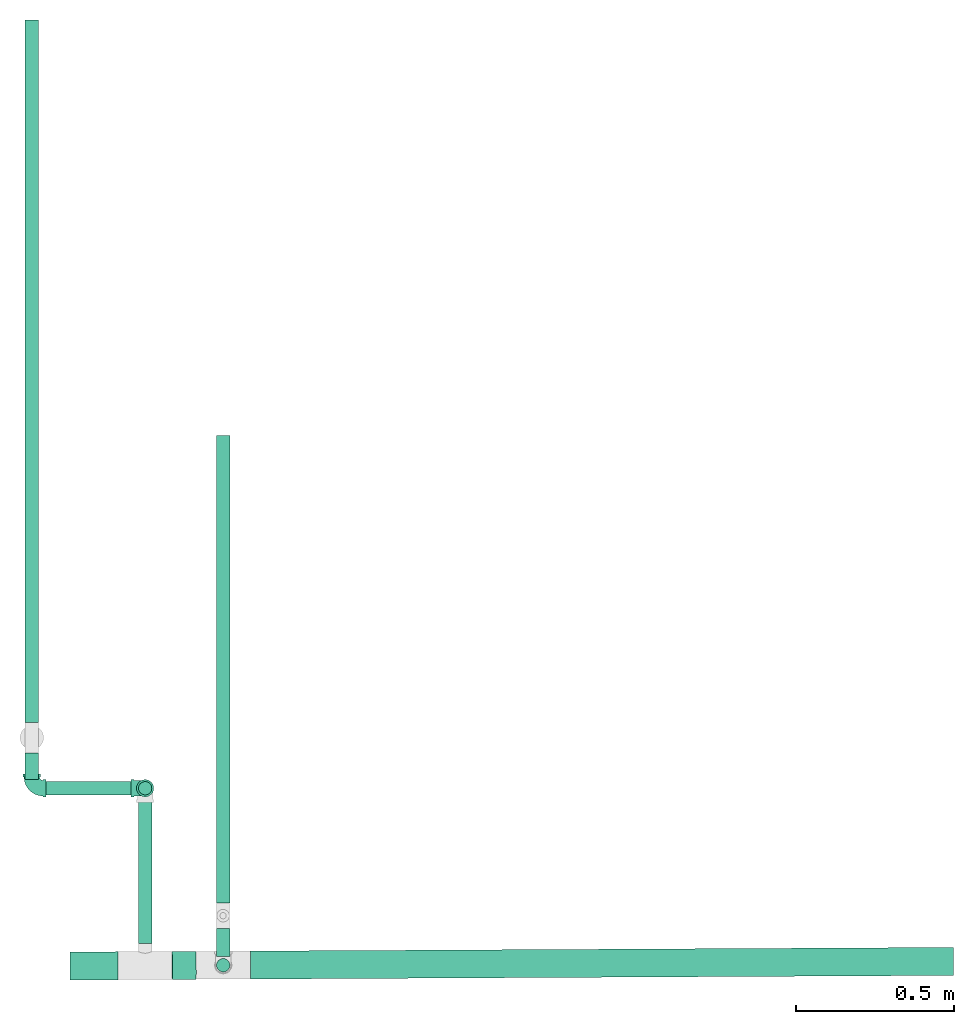
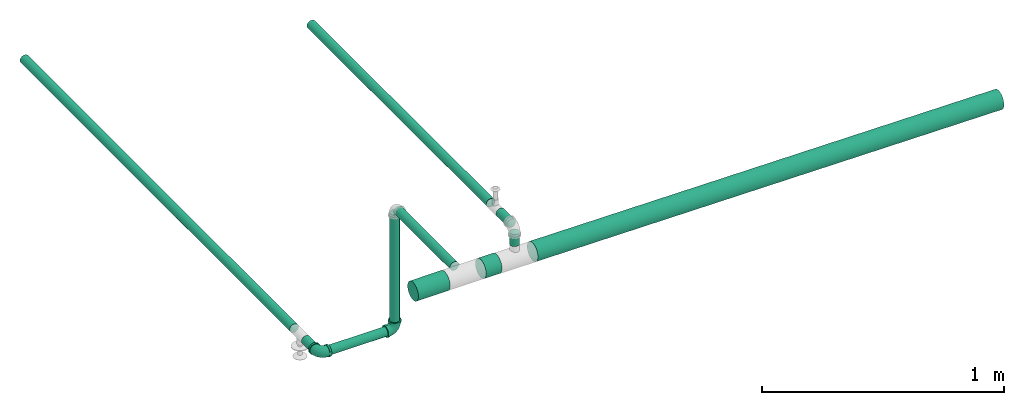
# One storey, part 1 of 7: 11 pipe segments, 2 pipe fittings.
"""IFC4 building model written with IfcOpenShell, lengths in millimetres."""

from ifc_helpers import new_model, entity, si_unit, converted_unit, derived_unit, direction, frame, frame_2d, origin, origin_2d_with_axis, place, context, subcontext, project, spatial, circle, extrude, source, transform, mapped, type_object, type_shapes, element, save


model = new_model("IFC4")

# Units and contexts
model_context = context("Model", 3, precision=0.01, world=origin(), true_north=direction((6.12303176911189e-17, 1.0)))
body_context = subcontext(model_context, "Body", "Model", "MODEL_VIEW")
ifc_project = project(units=[si_unit("LENGTHUNIT", "METRE", prefix="MILLI"), si_unit("AREAUNIT", "SQUARE_METRE"), si_unit("VOLUMEUNIT", "CUBIC_METRE"), converted_unit("PLANEANGLEUNIT", "DEGREE", entity("IfcRatioMeasure", 0.0174532925199433), si_unit("PLANEANGLEUNIT", "RADIAN"), dimensions=[0, 0, 0, 0, 0, 0, 0]), si_unit("MASSUNIT", "GRAM", prefix="KILO"), derived_unit("MASSDENSITYUNIT", [(si_unit("MASSUNIT", "GRAM", prefix="KILO"), 1), (si_unit("LENGTHUNIT", "METRE"), -3)]), derived_unit("MOMENTOFINERTIAUNIT", [(si_unit("LENGTHUNIT", "METRE"), 4)]), si_unit("TIMEUNIT", "SECOND"), si_unit("FREQUENCYUNIT", "HERTZ"), si_unit("THERMODYNAMICTEMPERATUREUNIT", "DEGREE_CELSIUS"), derived_unit("THERMALTRANSMITTANCEUNIT", [(si_unit("MASSUNIT", "GRAM", prefix="KILO"), 1), (si_unit("THERMODYNAMICTEMPERATUREUNIT", "KELVIN"), -1), (si_unit("TIMEUNIT", "SECOND"), -3)]), derived_unit("VOLUMETRICFLOWRATEUNIT", [(si_unit("LENGTHUNIT", "METRE"), 3), (si_unit("TIMEUNIT", "SECOND"), -1)]), si_unit("ELECTRICCURRENTUNIT", "AMPERE"), si_unit("ELECTRICVOLTAGEUNIT", "VOLT"), si_unit("POWERUNIT", "WATT"), si_unit("FORCEUNIT", "NEWTON", prefix="KILO"), si_unit("ILLUMINANCEUNIT", "LUX"), si_unit("LUMINOUSFLUXUNIT", "LUMEN"), si_unit("LUMINOUSINTENSITYUNIT", "CANDELA"), derived_unit("USERDEFINED", [(si_unit("MASSUNIT", "GRAM", prefix="KILO"), -1), (si_unit("LENGTHUNIT", "METRE"), -2), (si_unit("TIMEUNIT", "SECOND"), 3), (si_unit("LUMINOUSFLUXUNIT", "LUMEN"), 1)]), derived_unit("LINEARVELOCITYUNIT", [(si_unit("LENGTHUNIT", "METRE"), 1), (si_unit("TIMEUNIT", "SECOND"), -1)]), si_unit("PRESSUREUNIT", "PASCAL"), derived_unit("USERDEFINED", [(si_unit("LENGTHUNIT", "METRE"), -2), (si_unit("MASSUNIT", "GRAM", prefix="KILO"), 1), (si_unit("TIMEUNIT", "SECOND"), -2)]), derived_unit("LINEARFORCEUNIT", [(si_unit("MASSUNIT", "GRAM", prefix="KILO"), 1), (si_unit("LENGTHUNIT", "METRE"), 1), (si_unit("TIMEUNIT", "SECOND"), -2), (si_unit("LENGTHUNIT", "METRE"), -1)]), derived_unit("PLANARFORCEUNIT", [(si_unit("MASSUNIT", "GRAM", prefix="KILO"), 1), (si_unit("LENGTHUNIT", "METRE"), 1), (si_unit("TIMEUNIT", "SECOND"), -2), (si_unit("LENGTHUNIT", "METRE"), -2)])], contexts=[model_context])

# Site, building, storey
site_placement = place(None, origin())
site = spatial("IfcSite", under=ifc_project, at=site_placement, CompositionType="ELEMENT")
building_placement = place(site_placement, origin())
building = spatial("IfcBuilding", under=site, at=building_placement, CompositionType="ELEMENT")
storey_placement = place(building_placement, origin())
storey = spatial("IfcBuildingStorey", under=building, at=storey_placement, Name="Ebene 1", CompositionType="ELEMENT", Elevation=0.0)

# Pipe segments
pipe_segment_type = type_object("IfcPipeSegmentType", PredefinedType="NOTDEFINED")
pipe_segment_1_placement = place(storey_placement, frame((10752.7557828732, 94885.9064957971, 3701.44258339486)))
element("IfcPipeSegment", 1, at=pipe_segment_1_placement, inside=storey, type_object=pipe_segment_type, Name="2557", PredefinedType="NOTDEFINED", context=body_context, shape_type="SweptSolid", body=[
    extrude(circle(Radius=21.2, at=frame_2d((-9.62819385403469e-17, -1.73260207267188e-11), x_axis=(1.0, 0.0))), frame((22.7952719007182, 22.7952714513435, 0.00687981328899951), z_axis=(0.000177827791373917, 0.000272053912584841, 0.999999947181971), x_axis=(-0.999999984188637, 0.0, 0.000177827797954731)), (0.0, 0.0, 1.0), 60.1939504814704),
])
pipe_segment_2_placement = place(storey_placement, frame((10859.4947030414, 94863.1160077717, 3565.27971953889)))
element("IfcPipeSegment", 2, at=pipe_segment_2_placement, inside=storey, type_object=pipe_segment_type, Name="2560", PredefinedType="NOTDEFINED", context=body_context, shape_type="SweptSolid", body=[
    extrude(circle(Radius=44.45, at=frame_2d((1.12120611250361e-14, -1.96686733078511e-14), x_axis=(1.0, 0.0))), frame((2.05993232708415, 46.0446765665555, 66.3052599404551), z_axis=(0.999945358552014, 0.00517681182842612, -0.00908187918759944), x_axis=(-0.00517702533472437, 0.99998659911455, 0.0)), (0.0, 0.0, 1.0), 2231.0163407344),
])
pipe_segment_3_placement = place(storey_placement, frame((10752.7664866952, 94935.7631204171, 3765.88563724049)))
element("IfcPipeSegment", 3, at=pipe_segment_3_placement, inside=storey, type_object=pipe_segment_type, Name="2566", PredefinedType="NOTDEFINED", context=body_context, shape_type="SweptSolid", body=[
    extrude(circle(Radius=21.2, at=frame_2d((0.0, -5.41433564649196e-13), x_axis=(1.0, 0.0))), frame((22.7952722359154, 0.0, 22.7952722359154), z_axis=(0.0, 1.0, 0.0), x_axis=(1.0, 0.0, 0.0)), (0.0, 0.0, 1.0), 90.0010953566384),
])
pipe_segment_4_placement = place(storey_placement, frame((10752.7664866952, 95105.7642157737, 3765.88563724049)))
element("IfcPipeSegment", 4, at=pipe_segment_4_placement, inside=storey, type_object=pipe_segment_type, Name="2570", PredefinedType="NOTDEFINED", context=body_context, shape_type="SweptSolid", body=[
    extrude(circle(Radius=21.2, at=frame_2d((0.0, -5.41433564649196e-13), x_axis=(1.0, 0.0))), frame((22.7952722359154, 0.0, 22.7952722359154), z_axis=(0.0, 1.0, 0.0), x_axis=(1.0, 0.0, 0.0)), (0.0, 0.0, 1.0), 1483.54986643567),
])
pipe_segment_5_placement = place(storey_placement, frame((10504.9839035107, 94977.4117898509, 3610.5601586165)))
element("IfcPipeSegment", 5, at=pipe_segment_5_placement, inside=storey, type_object=pipe_segment_type, Name="2572", PredefinedType="NOTDEFINED", context=body_context, shape_type="SweptSolid", body=[
    extrude(circle(Radius=21.2, at=origin_2d_with_axis()), frame((22.7952722359154, 0.0218453948163187, 23.2752210845562), z_axis=(0.0, 0.999999469093314, -0.00103044315202733), x_axis=(1.0, 0.0, 0.0)), (0.0, 0.0, 1.0), 465.780283868985),
])
pipe_segment_6_placement = place(storey_placement, frame((10287.7463566771, 94860.1547981883, 3587.79010746514)))
element("IfcPipeSegment", 6, at=pipe_segment_6_placement, inside=storey, type_object=pipe_segment_type, Name="2574", PredefinedType="NOTDEFINED", context=body_context, shape_type="SweptSolid", body=[
    extrude(circle(Radius=44.45, at=frame_2d((0.0, 5.41433564649196e-13), x_axis=(1.0, 0.0))), frame((1.82539101204733, 46.0446765665555, 46.0452722359155), z_axis=(0.99998659911455, 0.00517702533479418, 0.0), x_axis=(-0.00517702533479418, 0.99998659911455, 0.0)), (0.0, 0.0, 1.0), 152.210620290662),
])
pipe_segment_7_placement = place(storey_placement, frame((10611.7180909433, 94861.8332447833, 3587.10362363127)))
element("IfcPipeSegment", 7, at=pipe_segment_7_placement, inside=storey, type_object=pipe_segment_type, Name="2577", PredefinedType="NOTDEFINED", context=body_context, shape_type="SweptSolid", body=[
    extrude(circle(Radius=44.45, at=origin_2d_with_axis()), frame((2.05993232708198, 46.0446765665728, 46.7317560697921), z_axis=(0.999945358552014, 0.00517681182839937, -0.00908187918760772), x_axis=(-0.00517702533469761, 0.99998659911455, 0.0)), (0.0, 0.0, 1.0), 75.7901517106951),
])
pipe_segment_8_placement = place(storey_placement, frame((10504.9756237539, 95447.4554323741, 3047.42526013098)))
element("IfcPipeSegment", 8, at=pipe_segment_8_placement, inside=storey, type_object=pipe_segment_type, Name="2580", PredefinedType="NOTDEFINED", context=body_context, shape_type="SweptSolid", body=[
    extrude(circle(Radius=21.2, at=origin_2d_with_axis()), frame((22.7952722335894, 22.7952722359111, 0.000314084892912092)), (0.0, 0.0, 1.0), 558.864484836124),
])
pipe_segment_9_placement = place(storey_placement, frame((10195.2442825675, 95447.4557013972, 2997.48561467216)))
element("IfcPipeSegment", 9, at=pipe_segment_9_placement, inside=storey, type_object=pipe_segment_type, Name="2584", PredefinedType="NOTDEFINED", context=body_context, shape_type="SweptSolid", body=[
    extrude(circle(Radius=21.2, at=origin_2d_with_axis()), frame((0.00046820902165905, 22.7952903068151, 22.7952722307458), z_axis=(1.0, -5.91540938050918e-08, 2.20853312261304e-05), x_axis=(5.91540938195183e-08, 1.0, 0.0)), (0.0, 0.0, 1.0), 305.48864550407),
])
pipe_segment_10_placement = place(storey_placement, frame((10145.4119785407, 95678.6449609939, 2998.04401196217)))
element("IfcPipeSegment", 10, at=pipe_segment_10_placement, inside=storey, type_object=pipe_segment_type, Name="2590", PredefinedType="NOTDEFINED", context=body_context, shape_type="SweptSolid", body=[
    extrude(circle(Radius=21.2, at=origin_2d_with_axis()), frame((22.7952722359154, 0.0567825635644567, 22.7951961919226), z_axis=(0.0, 0.999996413019192, 0.00267842281002645), x_axis=(1.0, 0.0, 0.0)), (0.0, 0.0, 1.0), 2229.45819114604),
])
pipe_segment_11_placement = place(storey_placement, frame((10145.4119785407, 95497.2316121575, 2997.55810856767)))
element("IfcPipeSegment", 11, at=pipe_segment_11_placement, inside=storey, type_object=pipe_segment_type, Name="2593", PredefinedType="NOTDEFINED", context=body_context, shape_type="SweptSolid", body=[
    extrude(circle(Radius=21.2, at=frame_2d((0.0, -5.41431622537391e-13), x_axis=(1.0, 0.0))), frame((22.7952722359154, 0.0567825635644567, 22.7951961919221), z_axis=(0.0, 0.999996413019192, 0.00267842281004059), x_axis=(1.0, 0.0, 0.0)), (0.0, 0.0, 1.0), 85.4139995650155),
])

# Pipe fittings
pipe_fitting_type = type_object("IfcPipeFittingType", Name="Threaded - Elbow - MI - Class 1:Standard 4", PredefinedType="NOTDEFINED")
cartesian_point_1 = entity("IfcCartesianPoint", [-44.4999999999936, -27.3500000000084, 0.0])
vertex_point_1 = entity("IfcVertexPoint", cartesian_point_1)
cartesian_point_2 = entity("IfcCartesianPoint", [-44.4999999999936, 27.3499999999916, 0.0])
vertex_point_2 = entity("IfcVertexPoint", cartesian_point_2)
cartesian_point_3 = entity("IfcCartesianPoint", [-44.4999999999936, 0.0, 0.0])
ifc_direction_1 = entity("IfcDirection", [-1.0, 0.0, 0.0])
ifc_direction_2 = entity("IfcDirection", [0.0, 1.0, 0.0])
edge_curve_1 = entity("IfcEdgeCurve", vertex_point_1, vertex_point_2, entity("IfcTrimmedCurve", entity("IfcCircle", entity("IfcAxis2Placement3D", cartesian_point_3, ifc_direction_1, ifc_direction_2), 27.35), [cartesian_point_1], [cartesian_point_2], True, "CARTESIAN"), True)
edge_curve_2 = entity("IfcEdgeCurve", vertex_point_2, vertex_point_1, entity("IfcTrimmedCurve", entity("IfcCircle", entity("IfcAxis2Placement3D", cartesian_point_3, ifc_direction_1, ifc_direction_2), 27.35), [cartesian_point_2], [cartesian_point_1], True, "CARTESIAN"), True)
cartesian_point_4 = entity("IfcCartesianPoint", [-44.4999999999936, 21.0819999999918, 0.0])
vertex_point_3 = entity("IfcVertexPoint", cartesian_point_4)
cartesian_point_5 = entity("IfcCartesianPoint", [-44.4999999999936, -21.0820000000082, 0.0])
vertex_point_4 = entity("IfcVertexPoint", cartesian_point_5)
ifc_direction_3 = entity("IfcDirection", [1.0, 0.0, 0.0])
edge_curve_3 = entity("IfcEdgeCurve", vertex_point_3, vertex_point_4, entity("IfcTrimmedCurve", entity("IfcCircle", entity("IfcAxis2Placement3D", cartesian_point_3, ifc_direction_3, ifc_direction_2), 21.082), [cartesian_point_4], [cartesian_point_5], True, "CARTESIAN"), True)
edge_curve_4 = entity("IfcEdgeCurve", vertex_point_4, vertex_point_3, entity("IfcTrimmedCurve", entity("IfcCircle", entity("IfcAxis2Placement3D", cartesian_point_3, ifc_direction_3, ifc_direction_2), 21.082), [cartesian_point_5], [cartesian_point_4], True, "CARTESIAN"), True)
ifc_direction_4 = entity("IfcDirection", [0.0, 0.0, 1.0])
cartesian_point_6 = entity("IfcCartesianPoint", [-35.7999999999934, 27.3499999999916, 0.0])
vertex_point_5 = entity("IfcVertexPoint", cartesian_point_6)
cartesian_point_7 = entity("IfcCartesianPoint", [-35.7999999999934, -27.3500000000084, 0.0])
vertex_point_6 = entity("IfcVertexPoint", cartesian_point_7)
cartesian_point_8 = entity("IfcCartesianPoint", [-35.7999999999934, 0.0, 0.0])
edge_curve_5 = entity("IfcEdgeCurve", vertex_point_5, vertex_point_6, entity("IfcTrimmedCurve", entity("IfcCircle", entity("IfcAxis2Placement3D", cartesian_point_8, ifc_direction_3, ifc_direction_2), 27.35), [cartesian_point_6], [cartesian_point_7], True, "CARTESIAN"), True)
edge_curve_6 = entity("IfcEdgeCurve", vertex_point_6, vertex_point_5, entity("IfcTrimmedCurve", entity("IfcCircle", entity("IfcAxis2Placement3D", cartesian_point_8, ifc_direction_3, ifc_direction_2), 27.35), [cartesian_point_7], [cartesian_point_6], True, "CARTESIAN"), True)
cartesian_point_9 = entity("IfcCartesianPoint", [-35.7999999999934, -24.7800000000084, 0.0])
vertex_point_7 = entity("IfcVertexPoint", cartesian_point_9)
cartesian_point_10 = entity("IfcCartesianPoint", [-35.7999999999934, 24.7799999999916, 0.0])
vertex_point_8 = entity("IfcVertexPoint", cartesian_point_10)
edge_curve_7 = entity("IfcEdgeCurve", vertex_point_7, vertex_point_8, entity("IfcTrimmedCurve", entity("IfcCircle", entity("IfcAxis2Placement3D", cartesian_point_8, ifc_direction_1, ifc_direction_2), 24.78), [cartesian_point_9], [cartesian_point_10], True, "CARTESIAN"), True)
edge_curve_8 = entity("IfcEdgeCurve", vertex_point_8, vertex_point_7, entity("IfcTrimmedCurve", entity("IfcCircle", entity("IfcAxis2Placement3D", cartesian_point_8, ifc_direction_1, ifc_direction_2), 24.78), [cartesian_point_10], [cartesian_point_9], True, "CARTESIAN"), True)
edge_curve_9 = entity("IfcEdgeCurve", vertex_point_1, vertex_point_6, entity("IfcTrimmedCurve", entity("IfcLine", cartesian_point_1, entity("IfcVector", ifc_direction_3, 304.8)), [cartesian_point_1], [cartesian_point_7], True, "CARTESIAN"), True)
edge_curve_10 = entity("IfcEdgeCurve", vertex_point_5, vertex_point_2, entity("IfcTrimmedCurve", entity("IfcLine", cartesian_point_2, entity("IfcVector", ifc_direction_1, 304.8)), [cartesian_point_6], [cartesian_point_2], True, "CARTESIAN"), True)
cartesian_point_11 = entity("IfcCartesianPoint", [-35.7999999999935, 21.0819999999918, 0.0])
vertex_point_9 = entity("IfcVertexPoint", cartesian_point_11)
edge_curve_11 = entity("IfcEdgeCurve", vertex_point_3, vertex_point_9, entity("IfcTrimmedCurve", entity("IfcLine", cartesian_point_11, entity("IfcVector", ifc_direction_3, 304.8)), [cartesian_point_4], [cartesian_point_11], True, "CARTESIAN"), True)
cartesian_point_12 = entity("IfcCartesianPoint", [-35.7999999999934, -21.0820000000082, 0.0])
vertex_point_10 = entity("IfcVertexPoint", cartesian_point_12)
edge_curve_12 = entity("IfcEdgeCurve", vertex_point_9, vertex_point_10, entity("IfcTrimmedCurve", entity("IfcCircle", entity("IfcAxis2Placement3D", cartesian_point_8, ifc_direction_3, ifc_direction_2), 21.082), [cartesian_point_11], [cartesian_point_12], True, "CARTESIAN"), True)
edge_curve_13 = entity("IfcEdgeCurve", vertex_point_10, vertex_point_4, entity("IfcTrimmedCurve", entity("IfcLine", cartesian_point_12, entity("IfcVector", ifc_direction_1, 304.8)), [cartesian_point_12], [cartesian_point_5], True, "CARTESIAN"), True)
cartesian_point_13 = entity("IfcCartesianPoint", [-27.0374999999917, 0.0, 0.0])
edge_curve_14 = entity("IfcEdgeCurve", vertex_point_10, vertex_point_9, entity("IfcTrimmedCurve", entity("IfcCircle", entity("IfcAxis2Placement3D", cartesian_point_8, ifc_direction_3, ifc_direction_2), 21.082), [cartesian_point_12], [cartesian_point_11], True, "CARTESIAN"), True)
cartesian_point_14 = entity("IfcCartesianPoint", [27.3500000000066, 35.7999999999916, 0.0])
vertex_point_11 = entity("IfcVertexPoint", cartesian_point_14)
cartesian_point_15 = entity("IfcCartesianPoint", [-27.3499999999934, 35.7999999999917, 0.0])
vertex_point_12 = entity("IfcVertexPoint", cartesian_point_15)
cartesian_point_16 = entity("IfcCartesianPoint", [0.0, 35.7999999999916, 0.0])
ifc_direction_5 = entity("IfcDirection", [0.0, -1.0, 0.0])
edge_curve_15 = entity("IfcEdgeCurve", vertex_point_11, vertex_point_12, entity("IfcTrimmedCurve", entity("IfcCircle", entity("IfcAxis2Placement3D", cartesian_point_16, ifc_direction_5, ifc_direction_1), 27.35), [cartesian_point_14], [cartesian_point_15], True, "CARTESIAN"), True)
edge_curve_16 = entity("IfcEdgeCurve", vertex_point_12, vertex_point_11, entity("IfcTrimmedCurve", entity("IfcCircle", entity("IfcAxis2Placement3D", cartesian_point_16, ifc_direction_5, ifc_direction_1), 27.35), [cartesian_point_15], [cartesian_point_14], True, "CARTESIAN"), True)
cartesian_point_17 = entity("IfcCartesianPoint", [-24.7799999999935, 35.7999999999917, 0.0])
vertex_point_13 = entity("IfcVertexPoint", cartesian_point_17)
cartesian_point_18 = entity("IfcCartesianPoint", [24.7800000000065, 35.7999999999916, 0.0])
vertex_point_14 = entity("IfcVertexPoint", cartesian_point_18)
edge_curve_17 = entity("IfcEdgeCurve", vertex_point_13, vertex_point_14, entity("IfcTrimmedCurve", entity("IfcCircle", entity("IfcAxis2Placement3D", cartesian_point_16, ifc_direction_2, ifc_direction_1), 24.78), [cartesian_point_17], [cartesian_point_18], True, "CARTESIAN"), True)
edge_curve_18 = entity("IfcEdgeCurve", vertex_point_14, vertex_point_13, entity("IfcTrimmedCurve", entity("IfcCircle", entity("IfcAxis2Placement3D", cartesian_point_16, ifc_direction_2, ifc_direction_1), 24.78), [cartesian_point_18], [cartesian_point_17], True, "CARTESIAN"), True)
cartesian_point_19 = entity("IfcCartesianPoint", [-27.3499999999934, 44.4999999999917, 0.0])
vertex_point_15 = entity("IfcVertexPoint", cartesian_point_19)
cartesian_point_20 = entity("IfcCartesianPoint", [27.3500000000066, 44.4999999999916, 0.0])
vertex_point_16 = entity("IfcVertexPoint", cartesian_point_20)
cartesian_point_21 = entity("IfcCartesianPoint", [0.0, 44.4999999999916, 0.0])
edge_curve_19 = entity("IfcEdgeCurve", vertex_point_15, vertex_point_16, entity("IfcTrimmedCurve", entity("IfcCircle", entity("IfcAxis2Placement3D", cartesian_point_21, ifc_direction_2, ifc_direction_1), 27.35), [cartesian_point_19], [cartesian_point_20], True, "CARTESIAN"), True)
edge_curve_20 = entity("IfcEdgeCurve", vertex_point_16, vertex_point_15, entity("IfcTrimmedCurve", entity("IfcCircle", entity("IfcAxis2Placement3D", cartesian_point_21, ifc_direction_2, ifc_direction_1), 27.35), [cartesian_point_20], [cartesian_point_19], True, "CARTESIAN"), True)
cartesian_point_22 = entity("IfcCartesianPoint", [0.0, 44.4999999999916, -21.081999999986])
vertex_point_17 = entity("IfcVertexPoint", cartesian_point_22)
cartesian_point_23 = entity("IfcCartesianPoint", [0.0, 44.4999999999916, 21.082000000014])
vertex_point_18 = entity("IfcVertexPoint", cartesian_point_23)
ifc_direction_6 = entity("IfcDirection", [0.0, 0.0, -1.0])
edge_curve_21 = entity("IfcEdgeCurve", vertex_point_17, vertex_point_18, entity("IfcTrimmedCurve", entity("IfcCircle", entity("IfcAxis2Placement3D", cartesian_point_21, ifc_direction_5, ifc_direction_6), 21.082), [cartesian_point_22], [cartesian_point_23], True, "CARTESIAN"), True)
edge_curve_22 = entity("IfcEdgeCurve", vertex_point_18, vertex_point_17, entity("IfcTrimmedCurve", entity("IfcCircle", entity("IfcAxis2Placement3D", cartesian_point_21, ifc_direction_5, ifc_direction_6), 21.082), [cartesian_point_23], [cartesian_point_22], True, "CARTESIAN"), True)
edge_curve_23 = entity("IfcEdgeCurve", vertex_point_11, vertex_point_16, entity("IfcTrimmedCurve", entity("IfcLine", cartesian_point_14, entity("IfcVector", ifc_direction_2, 304.8)), [cartesian_point_14], [cartesian_point_20], True, "CARTESIAN"), True)
edge_curve_24 = entity("IfcEdgeCurve", vertex_point_15, vertex_point_12, entity("IfcTrimmedCurve", entity("IfcLine", cartesian_point_15, entity("IfcVector", ifc_direction_5, 304.8)), [cartesian_point_19], [cartesian_point_15], True, "CARTESIAN"), True)
cartesian_point_24 = entity("IfcCartesianPoint", [0.0, 35.7999999999916, -21.081999999986])
vertex_point_19 = entity("IfcVertexPoint", cartesian_point_24)
edge_curve_25 = entity("IfcEdgeCurve", vertex_point_17, vertex_point_19, entity("IfcTrimmedCurve", entity("IfcLine", cartesian_point_24, entity("IfcVector", ifc_direction_5, 304.8)), [cartesian_point_22], [cartesian_point_24], True, "CARTESIAN"), True)
cartesian_point_25 = entity("IfcCartesianPoint", [0.0, 35.7999999999916, 21.082000000014])
vertex_point_20 = entity("IfcVertexPoint", cartesian_point_25)
edge_curve_26 = entity("IfcEdgeCurve", vertex_point_19, vertex_point_20, entity("IfcTrimmedCurve", entity("IfcCircle", entity("IfcAxis2Placement3D", cartesian_point_16, ifc_direction_5, ifc_direction_6), 21.082), [cartesian_point_24], [cartesian_point_25], True, "CARTESIAN"), True)
edge_curve_27 = entity("IfcEdgeCurve", vertex_point_20, vertex_point_18, entity("IfcTrimmedCurve", entity("IfcLine", cartesian_point_25, entity("IfcVector", ifc_direction_2, 304.8)), [cartesian_point_25], [cartesian_point_23], True, "CARTESIAN"), True)
cartesian_point_26 = entity("IfcCartesianPoint", [0.0, 27.0374999999898, 0.0])
edge_curve_28 = entity("IfcEdgeCurve", vertex_point_20, vertex_point_19, entity("IfcTrimmedCurve", entity("IfcCircle", entity("IfcAxis2Placement3D", cartesian_point_16, ifc_direction_5, ifc_direction_6), 21.082), [cartesian_point_25], [cartesian_point_24], True, "CARTESIAN"), True)
cartesian_point_27 = entity("IfcCartesianPoint", [-35.7999999999935, 35.7999999999916, 0.0])
edge_curve_29 = entity("IfcEdgeCurve", vertex_point_13, vertex_point_8, entity("IfcTrimmedCurve", entity("IfcCircle", entity("IfcAxis2Placement3D", cartesian_point_27, ifc_direction_6, ifc_direction_5), 11.02), [cartesian_point_17], [cartesian_point_10], True, "CARTESIAN"), True)
edge_curve_30 = entity("IfcEdgeCurve", vertex_point_7, vertex_point_14, entity("IfcTrimmedCurve", entity("IfcCircle", entity("IfcAxis2Placement3D", cartesian_point_27, ifc_direction_4, ifc_direction_5), 60.58), [cartesian_point_9], [cartesian_point_18], True, "CARTESIAN"), True)
shared_shape = source(origin(), body_context, "Body", "AdvancedBrep", [
    entity("IfcAdvancedBrep", entity("IfcClosedShell", [entity("IfcAdvancedFace", [entity("IfcFaceOuterBound", entity("IfcEdgeLoop", [entity("IfcOrientedEdge", None, None, edge_curve_1, True), entity("IfcOrientedEdge", None, None, edge_curve_2, True)]), True), entity("IfcFaceBound", entity("IfcEdgeLoop", [entity("IfcOrientedEdge", None, None, edge_curve_3, True), entity("IfcOrientedEdge", None, None, edge_curve_4, True)]), False)], entity("IfcPlane", entity("IfcAxis2Placement3D", cartesian_point_3, ifc_direction_1, ifc_direction_4)), True), entity("IfcAdvancedFace", [entity("IfcFaceOuterBound", entity("IfcEdgeLoop", [entity("IfcOrientedEdge", None, None, edge_curve_5, True), entity("IfcOrientedEdge", None, None, edge_curve_6, True)]), True), entity("IfcFaceBound", entity("IfcEdgeLoop", [entity("IfcOrientedEdge", None, None, edge_curve_7, True), entity("IfcOrientedEdge", None, None, edge_curve_8, True)]), False)], entity("IfcPlane", entity("IfcAxis2Placement3D", cartesian_point_8, ifc_direction_3, ifc_direction_4)), True), entity("IfcAdvancedFace", [entity("IfcFaceOuterBound", entity("IfcEdgeLoop", [entity("IfcOrientedEdge", None, None, edge_curve_1, False), entity("IfcOrientedEdge", None, None, edge_curve_9, True), entity("IfcOrientedEdge", None, None, edge_curve_5, False), entity("IfcOrientedEdge", None, None, edge_curve_10, True)]), True)], entity("IfcCylindricalSurface", entity("IfcAxis2Placement3D", cartesian_point_3, ifc_direction_1, ifc_direction_2), 27.35), True), entity("IfcAdvancedFace", [entity("IfcFaceOuterBound", entity("IfcEdgeLoop", [entity("IfcOrientedEdge", None, None, edge_curve_2, False), entity("IfcOrientedEdge", None, None, edge_curve_10, False), entity("IfcOrientedEdge", None, None, edge_curve_6, False), entity("IfcOrientedEdge", None, None, edge_curve_9, False)]), True)], entity("IfcCylindricalSurface", entity("IfcAxis2Placement3D", cartesian_point_3, ifc_direction_1, ifc_direction_2), 27.35), True), entity("IfcAdvancedFace", [entity("IfcFaceOuterBound", entity("IfcEdgeLoop", [entity("IfcOrientedEdge", None, None, edge_curve_3, False), entity("IfcOrientedEdge", None, None, edge_curve_11, True), entity("IfcOrientedEdge", None, None, edge_curve_12, True), entity("IfcOrientedEdge", None, None, edge_curve_13, True)]), True)], entity("IfcCylindricalSurface", entity("IfcAxis2Placement3D", cartesian_point_13, ifc_direction_1, ifc_direction_2), 21.082), False), entity("IfcAdvancedFace", [entity("IfcFaceOuterBound", entity("IfcEdgeLoop", [entity("IfcOrientedEdge", None, None, edge_curve_4, False), entity("IfcOrientedEdge", None, None, edge_curve_13, False), entity("IfcOrientedEdge", None, None, edge_curve_14, True), entity("IfcOrientedEdge", None, None, edge_curve_11, False)]), True)], entity("IfcCylindricalSurface", entity("IfcAxis2Placement3D", cartesian_point_13, ifc_direction_1, ifc_direction_2), 21.082), False), entity("IfcAdvancedFace", [entity("IfcFaceOuterBound", entity("IfcEdgeLoop", [entity("IfcOrientedEdge", None, None, edge_curve_15, True), entity("IfcOrientedEdge", None, None, edge_curve_16, True)]), True), entity("IfcFaceBound", entity("IfcEdgeLoop", [entity("IfcOrientedEdge", None, None, edge_curve_17, True), entity("IfcOrientedEdge", None, None, edge_curve_18, True)]), False)], entity("IfcPlane", entity("IfcAxis2Placement3D", cartesian_point_16, ifc_direction_5, ifc_direction_4)), True), entity("IfcAdvancedFace", [entity("IfcFaceOuterBound", entity("IfcEdgeLoop", [entity("IfcOrientedEdge", None, None, edge_curve_19, True), entity("IfcOrientedEdge", None, None, edge_curve_20, True)]), True), entity("IfcFaceBound", entity("IfcEdgeLoop", [entity("IfcOrientedEdge", None, None, edge_curve_21, True), entity("IfcOrientedEdge", None, None, edge_curve_22, True)]), False)], entity("IfcPlane", entity("IfcAxis2Placement3D", cartesian_point_21, ifc_direction_2, ifc_direction_4)), True), entity("IfcAdvancedFace", [entity("IfcFaceOuterBound", entity("IfcEdgeLoop", [entity("IfcOrientedEdge", None, None, edge_curve_15, False), entity("IfcOrientedEdge", None, None, edge_curve_23, True), entity("IfcOrientedEdge", None, None, edge_curve_19, False), entity("IfcOrientedEdge", None, None, edge_curve_24, True)]), True)], entity("IfcCylindricalSurface", entity("IfcAxis2Placement3D", cartesian_point_16, ifc_direction_5, ifc_direction_1), 27.35), True), entity("IfcAdvancedFace", [entity("IfcFaceOuterBound", entity("IfcEdgeLoop", [entity("IfcOrientedEdge", None, None, edge_curve_16, False), entity("IfcOrientedEdge", None, None, edge_curve_24, False), entity("IfcOrientedEdge", None, None, edge_curve_20, False), entity("IfcOrientedEdge", None, None, edge_curve_23, False)]), True)], entity("IfcCylindricalSurface", entity("IfcAxis2Placement3D", cartesian_point_16, ifc_direction_5, ifc_direction_1), 27.35), True), entity("IfcAdvancedFace", [entity("IfcFaceOuterBound", entity("IfcEdgeLoop", [entity("IfcOrientedEdge", None, None, edge_curve_21, False), entity("IfcOrientedEdge", None, None, edge_curve_25, True), entity("IfcOrientedEdge", None, None, edge_curve_26, True), entity("IfcOrientedEdge", None, None, edge_curve_27, True)]), True)], entity("IfcCylindricalSurface", entity("IfcAxis2Placement3D", cartesian_point_26, ifc_direction_2, ifc_direction_6), 21.082), False), entity("IfcAdvancedFace", [entity("IfcFaceOuterBound", entity("IfcEdgeLoop", [entity("IfcOrientedEdge", None, None, edge_curve_22, False), entity("IfcOrientedEdge", None, None, edge_curve_27, False), entity("IfcOrientedEdge", None, None, edge_curve_28, True), entity("IfcOrientedEdge", None, None, edge_curve_25, False)]), True)], entity("IfcCylindricalSurface", entity("IfcAxis2Placement3D", cartesian_point_26, ifc_direction_2, ifc_direction_6), 21.082), False), entity("IfcAdvancedFace", [entity("IfcFaceOuterBound", entity("IfcEdgeLoop", [entity("IfcOrientedEdge", None, None, edge_curve_12, False), entity("IfcOrientedEdge", None, None, edge_curve_14, False)]), True)], entity("IfcPlane", entity("IfcAxis2Placement3D", cartesian_point_8, ifc_direction_1, ifc_direction_4)), True), entity("IfcAdvancedFace", [entity("IfcFaceOuterBound", entity("IfcEdgeLoop", [entity("IfcOrientedEdge", None, None, edge_curve_26, False), entity("IfcOrientedEdge", None, None, edge_curve_28, False)]), True)], entity("IfcPlane", entity("IfcAxis2Placement3D", cartesian_point_16, ifc_direction_2, ifc_direction_4)), True), entity("IfcAdvancedFace", [entity("IfcFaceOuterBound", entity("IfcEdgeLoop", [entity("IfcOrientedEdge", None, None, edge_curve_29, True), entity("IfcOrientedEdge", None, None, edge_curve_7, False), entity("IfcOrientedEdge", None, None, edge_curve_30, True), entity("IfcOrientedEdge", None, None, edge_curve_17, False)]), True)], entity("IfcSurfaceOfRevolution", entity("IfcArbitraryOpenProfileDef", "CURVE", None, entity("IfcTrimmedCurve", entity("IfcCircle", entity("IfcAxis2Placement3D", cartesian_point_16, ifc_direction_5, ifc_direction_1), 24.78), [cartesian_point_18], [cartesian_point_17], True, "CARTESIAN")), None, entity("IfcAxis1Placement", cartesian_point_27, ifc_direction_4)), True), entity("IfcAdvancedFace", [entity("IfcFaceOuterBound", entity("IfcEdgeLoop", [entity("IfcOrientedEdge", None, None, edge_curve_29, False), entity("IfcOrientedEdge", None, None, edge_curve_18, False), entity("IfcOrientedEdge", None, None, edge_curve_30, False), entity("IfcOrientedEdge", None, None, edge_curve_8, False)]), True)], entity("IfcSurfaceOfRevolution", entity("IfcArbitraryOpenProfileDef", "CURVE", None, entity("IfcTrimmedCurve", entity("IfcCircle", entity("IfcAxis2Placement3D", cartesian_point_16, ifc_direction_5, ifc_direction_1), 24.78), [cartesian_point_17], [cartesian_point_18], True, "CARTESIAN")), None, entity("IfcAxis1Placement", cartesian_point_27, ifc_direction_4)), True)])),
])
type_shapes(pipe_fitting_type, [shared_shape])
for number, where, z_axis, x_axis, name in (
    (12, (10527.7708959875, 95470.2507046101, 3020.38807421589), (0.0, 1.0, 0.0), (0.0, 0.0, -1.0), "Threaded - Elbow - MI - Class 1:Standard 4:2586"),
    (13, (10168.2072507766, 95470.250991704, 3020.2808869029), (0.0, -0.00267842281002751, 0.999996413019192), (0.0, -0.999996413019192, -0.00267842281002751), "Threaded - Elbow - MI - Class 1:Standard 4:2588"),
):
    element("IfcPipeFitting", number, at=place(storey_placement, frame(where, z_axis=z_axis, x_axis=x_axis)), inside=storey, type_object=pipe_fitting_type, Name=name, ObjectType="Threaded - Elbow - MI - Class 1:Standard 4", PredefinedType="NOTDEFINED", context=body_context, shape_type="MappedRepresentation", body=[
        mapped(shared_shape, transform((0.0, 0.0, 0.0), scale=1.0)),
    ])

save(model, "model.ifc")
